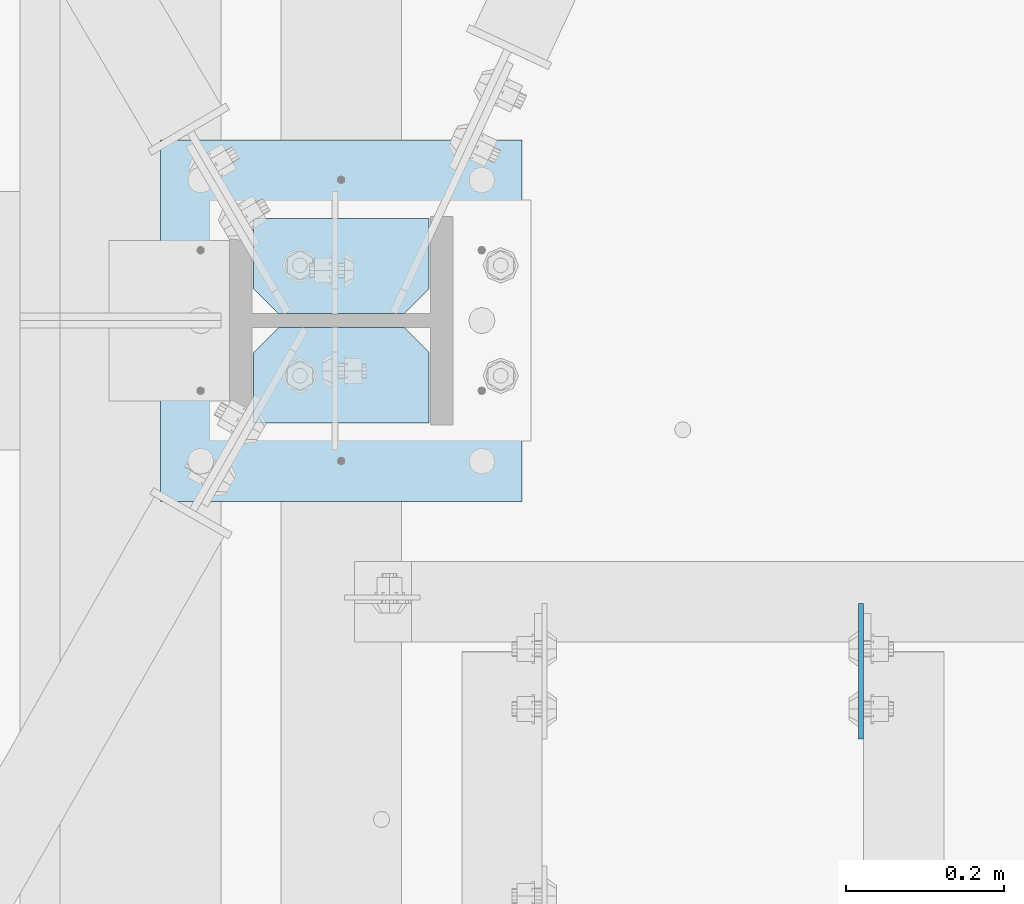
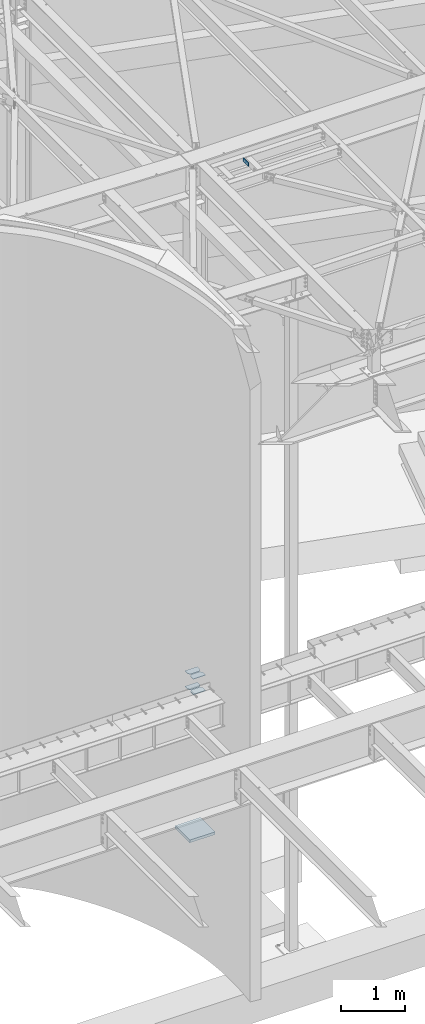
# One storey, part 1652 of 1763: 6 plates, 2 elements without a shape of their own.
"""IFC2X3 building model written with IfcOpenShell, lengths in millimetres."""

from ifc_helpers import new_model, si_unit, frame, origin_with_axes, place, context, subcontext, project, spatial, faceted_brep, material, type_object, element, aggregate, save


model = new_model("IFC2X3")

# Units and contexts
model_context = context("Model", 3, precision=1e-05, world=origin_with_axes())
body_context = subcontext(model_context, "Body", "Model", "MODEL_VIEW")
ifc_project = project(units=[si_unit("LENGTHUNIT", "METRE", prefix="MILLI"), si_unit("AREAUNIT", "SQUARE_METRE"), si_unit("VOLUMEUNIT", "CUBIC_METRE"), si_unit("MASSUNIT", "GRAM", prefix="KILO"), si_unit("TIMEUNIT", "SECOND"), si_unit("PLANEANGLEUNIT", "RADIAN"), si_unit("SOLIDANGLEUNIT", "STERADIAN"), si_unit("THERMODYNAMICTEMPERATUREUNIT", "DEGREE_CELSIUS"), si_unit("LUMINOUSINTENSITYUNIT", "LUMEN")], contexts=[model_context])

# Site, building, storey
site_placement = place(None, origin_with_axes())
site = spatial("IfcSite", under=ifc_project, at=site_placement, CompositionType="ELEMENT")
building_placement = place(site_placement, origin_with_axes())
building = spatial("IfcBuilding", under=site, at=building_placement, Name="Undefined", CompositionType="ELEMENT")
storey_placement = place(building_placement, origin_with_axes())
storey = spatial("IfcBuildingStorey", under=building, at=storey_placement, Name="Undefined", CompositionType="ELEMENT", Elevation=0.0)

# Assembly, plate
assembly_1_placement = place(storey_placement, origin_with_axes())
assembly_1 = element("IfcElementAssembly", 1, at=assembly_1_placement, inside=storey, Name="BEAM", AssemblyPlace="NOTDEFINED", PredefinedType="RIGID_FRAME")
ifc_material = material(Name="STEEL/A36")
plate_type_1 = type_object("IfcPlateType", PredefinedType="NOTDEFINED")
plate_1_placement = place(assembly_1_placement, frame((-39015.0646174483, 57344.4687499993, 12420.6), z_axis=(0.0, -1.0, 0.0), x_axis=(0.0, 0.0, -1.0)))
plate_1 = element("IfcPlate", 2, at=plate_1_placement, type_object=plate_type_1, material=ifc_material, Name="PLATE", context=body_context, shape_type="Brep", body=[
    faceted_brep([(1.81898940354586e-12, -3.17500000000291, 0.0), (0.0, -3.17500000000291, 171.449996948242), (0.0, 3.17500000000291, 171.449996948242), (-1.81898940354586e-12, 3.17499999997381, 0.0), (76.1999969482422, -3.17500000000291, 171.449996948242), (76.1999969482422, 3.17500000000291, 171.449996948242), (76.1999969482422, -3.17500000000291, 0.0), (76.1999969482422, 3.17500000000291, 0.0)], [[[0, 1, 2, 3]], [[1, 4, 5, 2]], [[4, 6, 7, 5]], [[6, 0, 3, 7]], [[5, 7, 3, 2]], [[6, 4, 1, 0]]]),
])
aggregate(assembly_1, [plate_1])

# Assembly, plates
assembly_2_placement = place(storey_placement, origin_with_axes())
assembly_2 = element("IfcElementAssembly", 3, at=assembly_2_placement, inside=storey, Name="COLUMN", AssemblyPlace="NOTDEFINED", PredefinedType="RIGID_FRAME")
plate_type_2 = type_object("IfcPlateType", PredefinedType="NOTDEFINED")
plate_2_placement = place(assembly_2_placement, frame((-39561.1646174484, 57573.06875, 2303.4625), z_axis=(-1.0, 0.0, 0.0), x_axis=(0.0, 1.0, 0.0)))
plate_2 = element("IfcPlate", 4, at=plate_2_placement, type_object=plate_type_2, material=ifc_material, Name="PLATE", context=body_context, shape_type="Brep", body=[
    faceted_brep([(0.0, -4.76249999999982, 0.0), (0.0, -4.76250000000073, 222.25), (0.0, 4.76250000000073, 222.25), (0.0, 4.76249999999982, 0.0), (88.9000015258789, -4.76250000000073, 222.25), (88.9000015258789, 4.76250000000073, 222.25), (120.650001525879, -4.76250000000073, 190.5), (120.650001525879, 4.76250000000073, 190.5), (120.650001525879, -4.76249999999709, 31.75), (120.650001525879, 4.76249999999709, 31.75), (88.9000015258789, -4.76249999999709, 0.0), (88.9000015258789, 4.76249999999709, 0.0)], [[[0, 1, 2, 3]], [[1, 4, 5, 2]], [[4, 6, 7, 5]], [[6, 8, 9, 7]], [[8, 10, 11, 9]], [[10, 0, 3, 11]], [[5, 7, 9, 11, 3, 2]], [[10, 8, 6, 4, 1, 0]]]),
])
plate_3_placement = place(assembly_2_placement, frame((-39561.1646174484, 57711.18125, 2303.4625), z_axis=(-1.0, 0.0, 0.0), x_axis=(0.0, 1.0, 0.0)))
plate_3 = element("IfcPlate", 5, at=plate_3_placement, type_object=plate_type_2, material=ifc_material, Name="PLATE", context=body_context, shape_type="Brep", body=[
    faceted_brep([(0.0, -4.76250000000073, 31.75), (0.0, -4.76250000000073, 190.5), (0.0, 4.76250000000073, 190.5), (0.0, 4.76250000000073, 31.75), (31.75, -4.76250000000073, 222.25), (31.75, 4.76250000000073, 222.25), (120.650001525879, -4.76250000000073, 222.25), (120.650001525879, 4.76250000000073, 222.25), (120.650001525879, -4.76249999999709, 0.0), (120.650001525879, 4.76249999999709, 0.0), (31.75, -4.76250000000073, 0.0), (31.75, 4.76250000000073, 0.0)], [[[0, 1, 2, 3]], [[1, 4, 5, 2]], [[4, 6, 7, 5]], [[6, 8, 9, 7]], [[8, 10, 11, 9]], [[10, 0, 3, 11]], [[5, 7, 9, 11, 3, 2]], [[10, 8, 6, 4, 1, 0]]]),
])
plate_4_placement = place(assembly_2_placement, frame((-39561.1646174484, 57573.06875, 2598.7375), z_axis=(-1.0, 0.0, 0.0), x_axis=(0.0, 1.0, 0.0)))
plate_4 = element("IfcPlate", 6, at=plate_4_placement, type_object=plate_type_2, material=ifc_material, Name="PLATE", context=body_context, shape_type="Brep", body=[
    faceted_brep([(0.0, -4.76249999999982, 0.0), (0.0, -4.76250000000073, 222.25), (0.0, 4.76250000000073, 222.25), (0.0, 4.76249999999982, 0.0), (88.9000015258789, -4.76250000000073, 222.25), (88.9000015258789, 4.76250000000073, 222.25), (120.650001525879, -4.76250000000073, 190.5), (120.650001525879, 4.76250000000073, 190.5), (120.650001525879, -4.76249999999709, 31.75), (120.650001525879, 4.76249999999709, 31.75), (88.9000015258789, -4.76249999999709, 0.0), (88.9000015258789, 4.76249999999709, 0.0)], [[[0, 1, 2, 3]], [[1, 4, 5, 2]], [[4, 6, 7, 5]], [[6, 8, 9, 7]], [[8, 10, 11, 9]], [[10, 0, 3, 11]], [[5, 7, 9, 11, 3, 2]], [[10, 8, 6, 4, 1, 0]]]),
])
plate_5_placement = place(assembly_2_placement, frame((-39561.1646174484, 57711.18125, 2598.7375), z_axis=(-1.0, 0.0, 0.0), x_axis=(0.0, 1.0, 0.0)))
plate_5 = element("IfcPlate", 7, at=plate_5_placement, type_object=plate_type_2, material=ifc_material, Name="PLATE", context=body_context, shape_type="Brep", body=[
    faceted_brep([(0.0, -4.76250000000073, 31.75), (0.0, -4.76250000000073, 190.5), (0.0, 4.76250000000073, 190.5), (0.0, 4.76250000000073, 31.75), (31.75, -4.76250000000073, 222.25), (31.75, 4.76250000000073, 222.25), (120.650001525879, -4.76250000000073, 222.25), (120.650001525879, 4.76250000000073, 222.25), (120.650001525879, -4.76249999999709, 0.0), (120.650001525879, 4.76249999999709, 0.0), (31.75, -4.76250000000073, 0.0), (31.75, 4.76250000000073, 0.0)], [[[0, 1, 2, 3]], [[1, 4, 5, 2]], [[4, 6, 7, 5]], [[6, 8, 9, 7]], [[8, 10, 11, 9]], [[10, 0, 3, 11]], [[5, 7, 9, 11, 3, 2]], [[10, 8, 6, 4, 1, 0]]]),
])
plate_type_3 = type_object("IfcPlateType", PredefinedType="NOTDEFINED")
plate_6_placement = place(assembly_2_placement, frame((-39900.8896174484, 57473.85, -393.7), z_axis=(0.0, 1.0, 0.0), x_axis=(1.0, 0.0, 0.0)))
plate_6 = element("IfcPlate", 8, at=plate_6_placement, type_object=plate_type_3, material=ifc_material, Name="PLATE", context=body_context, shape_type="Brep", body=[
    faceted_brep([(0.0, -25.4000000000015, 0.0), (0.0, -25.4, 457.200012207031), (0.0, 25.4, 457.200012207031), (0.0, 25.4000000000015, 0.0), (457.200012207031, -25.4, 457.200012207031), (457.200012207031, 25.4, 457.200012207031), (457.200012207031, -25.4, 0.0), (457.200012207031, 25.4, 0.0)], [[[0, 1, 2, 3]], [[1, 4, 5, 2]], [[4, 6, 7, 5]], [[6, 0, 3, 7]], [[5, 7, 3, 2]], [[6, 4, 1, 0]]]),
])
aggregate(assembly_2, [plate_2, plate_3, plate_4, plate_5, plate_6])

save(model, "model.ifc")
